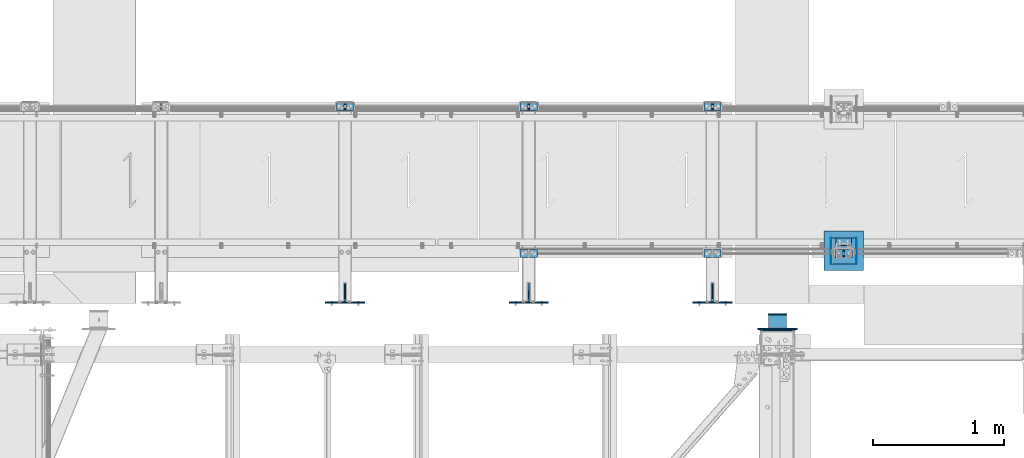
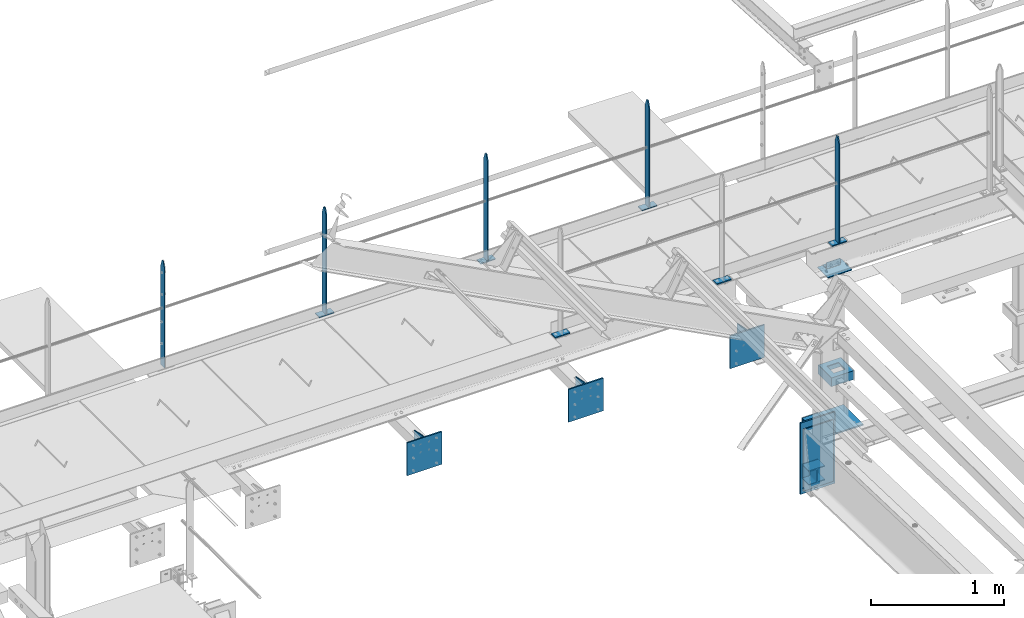
# One storey, part 96 of 496: 29 beams, 11 elements without a shape of their own.
"""IFC2X3 building model written with IfcOpenShell, lengths in millimetres."""

from ifc_helpers import new_model, si_unit, frame, origin_with_axes, origin_2d_with_axis, place, context, subcontext, project, spatial, polyline, rectangle, i_section, l_section, u_section, outline, extrude, boolean, clip, halfspace, material, type_object, element, aggregate, save


model = new_model("IFC2X3")

# Units and contexts
model_context = context("Model", 3, precision=1e-05, world=origin_with_axes())
body_context = subcontext(model_context, "Body", "Model", "MODEL_VIEW")
ifc_project = project(units=[si_unit("LENGTHUNIT", "METRE", prefix="MILLI"), si_unit("AREAUNIT", "SQUARE_METRE"), si_unit("VOLUMEUNIT", "CUBIC_METRE"), si_unit("MASSUNIT", "GRAM", prefix="KILO"), si_unit("TIMEUNIT", "SECOND"), si_unit("PLANEANGLEUNIT", "RADIAN"), si_unit("SOLIDANGLEUNIT", "STERADIAN"), si_unit("THERMODYNAMICTEMPERATUREUNIT", "DEGREE_CELSIUS"), si_unit("LUMINOUSINTENSITYUNIT", "LUMEN")], contexts=[model_context])

# Site, building, storey
site_placement = place(None, origin_with_axes())
site = spatial("IfcSite", under=ifc_project, at=site_placement, CompositionType="ELEMENT")
building_placement = place(site_placement, origin_with_axes())
building = spatial("IfcBuilding", under=site, at=building_placement, Name="Undefined", CompositionType="ELEMENT")
storey_placement = place(building_placement, origin_with_axes())
storey = spatial("IfcBuildingStorey", under=building, at=storey_placement, Name="Undefined", CompositionType="ELEMENT", Elevation=0.0)

# Assembly, beams
assembly_1_placement = place(storey_placement, origin_with_axes())
assembly_1 = element("IfcElementAssembly", 1, at=assembly_1_placement, inside=storey, Name="MAIN COURANTE", AssemblyPlace="NOTDEFINED", PredefinedType="NOTDEFINED")
ifc_material_1 = material(Name="Undefined/S235-E24")
beam_type_1 = type_object("IfcBeamType", PredefinedType="NOTDEFINED")
beam_1_placement = place(assembly_1_placement, frame((20119.9961849157, 15970.0000882977, 8705.00000001012), z_axis=(0.0, -1.0, 0.0), x_axis=(-1.0, 0.0, 0.0)))
beam_1 = element("IfcBeam", 2, at=beam_1_placement, type_object=beam_type_1, material=ifc_material_1, context=body_context, shape_type="SweptSolid", body=[
    extrude(rectangle(XDim=10.0, YDim=60.0, at=origin_2d_with_axis()), frame((130.0, 0.0, 0.0), z_axis=(-1.0, 0.0, 0.0), x_axis=(0.0, -1.0, 0.0)), (0.0, 0.0, 1.0), 130.0),
])
beam_2_placement = place(assembly_1_placement, frame((20054.9961849157, 15970.0000882977, 9677.59999847), z_axis=(0.0, 1.0, 0.0), x_axis=(0.0, 0.0, -1.0)))
beam_2 = element("IfcBeam", 3, at=beam_2_placement, type_object=beam_type_1, material=ifc_material_1, Name="MONTANT", context=body_context, shape_type="Clipping", body=[
    clip(clip(extrude(rectangle(XDim=10.0, YDim=60.0, at=origin_2d_with_axis()), frame((967.59999845988, 0.0, 0.0), z_axis=(-1.0, 0.0, 0.0), x_axis=(0.0, -1.0, 0.0)), (0.0, 0.0, 1.0), 967.6), halfspace(frame((-120.0, -5.0, -30.0), z_axis=(-0.316227766016838, 0.0, 0.948683298050514), x_axis=(0.0, 1.0, 0.0)), False)), halfspace(frame((60.0, -5.0, -30.0), z_axis=(-0.316227766016838, 0.0, -0.948683298050514), x_axis=(0.0, 1.0, 0.0)), False)),
])
beam_3_placement = place(assembly_1_placement, frame((19119.9961849193, 15970.0000882977, 8705.00000001012), z_axis=(0.0, -1.0, 0.0), x_axis=(-1.0, 0.0, 0.0)))
beam_3 = element("IfcBeam", 4, at=beam_3_placement, type_object=beam_type_1, material=ifc_material_1, context=body_context, shape_type="SweptSolid", body=[
    extrude(rectangle(XDim=10.0, YDim=60.0, at=origin_2d_with_axis()), frame((130.0, 0.0, 0.0), z_axis=(-1.0, 0.0, 0.0), x_axis=(0.0, -1.0, 0.0)), (0.0, 0.0, 1.0), 130.0),
])
aggregate(assembly_1, [beam_1, beam_2, beam_3])

# Assembly, beam
assembly_2_placement = place(storey_placement, origin_with_axes())
assembly_2 = element("IfcElementAssembly", 5, at=assembly_2_placement, inside=storey, AssemblyPlace="NOTDEFINED", PredefinedType="NOTDEFINED")
beam_4_placement = place(assembly_2_placement, frame((17719.9961849193, 15970.0000882977, 8705.00000001012), z_axis=(0.0, -1.0, 0.0), x_axis=(-1.0, 0.0, 0.0)))
beam_4 = element("IfcBeam", 6, at=beam_4_placement, type_object=beam_type_1, material=ifc_material_1, context=body_context, shape_type="SweptSolid", body=[
    extrude(rectangle(XDim=10.0, YDim=60.0, at=origin_2d_with_axis()), frame((130.0, 0.0, 0.0), z_axis=(-1.0, 0.0, 0.0), x_axis=(0.0, -1.0, 0.0)), (0.0, 0.0, 1.0), 130.0),
])
aggregate(assembly_2, [beam_4])

# Assembly, beams
assembly_3_placement = place(storey_placement, origin_with_axes())
assembly_3 = element("IfcElementAssembly", 7, at=assembly_3_placement, inside=storey, Name="MAIN COURANTE", AssemblyPlace="NOTDEFINED", PredefinedType="NOTDEFINED")
beam_5_placement = place(assembly_3_placement, frame((19119.9961849193, 17089.9938659712, 8705.00000001012), z_axis=(0.0, 1.0, 0.0), x_axis=(-1.0, 0.0, 0.0)))
beam_5 = element("IfcBeam", 8, at=beam_5_placement, type_object=beam_type_1, material=ifc_material_1, context=body_context, shape_type="SweptSolid", body=[
    extrude(rectangle(XDim=10.0, YDim=60.0, at=origin_2d_with_axis()), frame((130.0, 0.0, 0.0), z_axis=(-1.0, 0.0, 0.0), x_axis=(0.0, -1.0, 0.0)), (0.0, 0.0, 1.0), 130.0),
])
beam_6_placement = place(assembly_3_placement, frame((17719.9961849193, 17089.9938659712, 8705.00000001012), z_axis=(0.0, 1.0, 0.0), x_axis=(-1.0, 0.0, 0.0)))
beam_6 = element("IfcBeam", 9, at=beam_6_placement, type_object=beam_type_1, material=ifc_material_1, context=body_context, shape_type="SweptSolid", body=[
    extrude(rectangle(XDim=10.0, YDim=60.0, at=origin_2d_with_axis()), frame((130.0, 0.0, 0.0), z_axis=(-1.0, 0.0, 0.0), x_axis=(0.0, -1.0, 0.0)), (0.0, 0.0, 1.0), 130.0),
])
beam_7_placement = place(assembly_3_placement, frame((16319.9961849193, 17089.9938659712, 8705.00000001012), z_axis=(0.0, 1.0, 0.0), x_axis=(-1.0, 0.0, 0.0)))
beam_7 = element("IfcBeam", 10, at=beam_7_placement, type_object=beam_type_1, material=ifc_material_1, context=body_context, shape_type="SweptSolid", body=[
    extrude(rectangle(XDim=10.0, YDim=60.0, at=origin_2d_with_axis()), frame((130.0, 0.0, 0.0), z_axis=(-1.0, 0.0, 0.0), x_axis=(0.0, -1.0, 0.0)), (0.0, 0.0, 1.0), 130.0),
])
beam_8_placement = place(assembly_3_placement, frame((16254.9961849193, 17089.9938659712, 9677.59999847), z_axis=(0.0, -1.0, 0.0), x_axis=(0.0, 0.0, -1.0)))
beam_8 = element("IfcBeam", 11, at=beam_8_placement, type_object=beam_type_1, material=ifc_material_1, Name="MONTANT", context=body_context, shape_type="Clipping", body=[
    clip(clip(extrude(rectangle(XDim=10.0, YDim=60.0, at=origin_2d_with_axis()), frame((967.59999845988, 0.0, 0.0), z_axis=(-1.0, 0.0, 0.0), x_axis=(0.0, -1.0, 0.0)), (0.0, 0.0, 1.0), 967.6), halfspace(frame((-120.0, 5.0, -30.0), z_axis=(-0.316227766016838, 0.0, 0.948683298050514), x_axis=(0.948683298050514, 0.0, 0.316227766016838)), False)), halfspace(frame((60.0, 5.0, -30.0), z_axis=(-0.316227766016838, 0.0, -0.948683298050514), x_axis=(-0.948683298050514, 0.0, 0.316227766016838)), False)),
])
beam_9_placement = place(assembly_3_placement, frame((17654.9961849193, 17089.9938659712, 9677.59999847), z_axis=(0.0, -1.0, 0.0), x_axis=(0.0, 0.0, -1.0)))
beam_9 = element("IfcBeam", 12, at=beam_9_placement, type_object=beam_type_1, material=ifc_material_1, Name="MONTANT", context=body_context, shape_type="Clipping", body=[
    clip(clip(extrude(rectangle(XDim=10.0, YDim=60.0, at=origin_2d_with_axis()), frame((967.59999845988, 0.0, 0.0), z_axis=(-1.0, 0.0, 0.0), x_axis=(0.0, -1.0, 0.0)), (0.0, 0.0, 1.0), 967.6), halfspace(frame((-120.0, 5.0, -30.0), z_axis=(-0.316227766016838, 0.0, 0.948683298050514), x_axis=(0.948683298050514, 0.0, 0.316227766016838)), False)), halfspace(frame((60.0, 5.0, -30.0), z_axis=(-0.316227766016838, 0.0, -0.948683298050514), x_axis=(-0.948683298050514, 0.0, 0.316227766016838)), False)),
])
beam_10_placement = place(assembly_3_placement, frame((19054.9961849193, 17089.9938659712, 9677.59999847), z_axis=(0.0, -1.0, 0.0), x_axis=(0.0, 0.0, -1.0)))
beam_10 = element("IfcBeam", 13, at=beam_10_placement, type_object=beam_type_1, material=ifc_material_1, Name="MONTANT", context=body_context, shape_type="Clipping", body=[
    clip(clip(extrude(rectangle(XDim=10.0, YDim=60.0, at=origin_2d_with_axis()), frame((967.59999845988, 0.0, 0.0), z_axis=(-1.0, 0.0, 0.0), x_axis=(0.0, -1.0, 0.0)), (0.0, 0.0, 1.0), 967.6), halfspace(frame((-120.0, 5.0, -30.0), z_axis=(-0.316227766016838, 0.0, 0.948683298050514), x_axis=(0.948683298050514, 0.0, 0.316227766016838)), False)), halfspace(frame((60.0, 5.0, -30.0), z_axis=(-0.316227766016838, 0.0, -0.948683298050514), x_axis=(-0.948683298050514, 0.0, 0.316227766016838)), False)),
])
aggregate(assembly_3, [beam_5, beam_6, beam_7, beam_8, beam_9, beam_10])

# Assembly, beam
assembly_4_placement = place(storey_placement, origin_with_axes())
assembly_4 = element("IfcElementAssembly", 14, at=assembly_4_placement, inside=storey, Name="CONSOLE", AssemblyPlace="NOTDEFINED", PredefinedType="NOTDEFINED")
beam_type_2 = type_object("IfcBeamType", PredefinedType="NOTDEFINED")
beam_11_placement = place(assembly_4_placement, frame((19055.0007605158, 15622.0, 8175.0), z_axis=(-1.0, 0.0, 0.0), x_axis=(0.0, -1.0, 0.0)))
beam_11 = element("IfcBeam", 15, at=beam_11_placement, type_object=beam_type_2, material=ifc_material_1, Name="CONSOLE", context=body_context, shape_type="SweptSolid", body=[
    extrude(outline(polyline([(0.0, 0.0), (20.0, 0.0), (20.0, 300.0), (0.0, 300.0), (-118.0, 275.0), (-118.0, 155.0), (0.0, 0.0)])), frame((0.0, 0.0, -4.0), z_axis=(0.0, 0.0, 1.0), x_axis=(1.0, 0.0, 0.0)), (0.0, 0.0, 1.0), 8.0),
])

assembly_5_placement = place(storey_placement, origin_with_axes())
assembly_5 = element("IfcElementAssembly", 16, at=assembly_5_placement, inside=storey, Name="CONSOLE", AssemblyPlace="NOTDEFINED", PredefinedType="NOTDEFINED")
beam_12_placement = place(assembly_5_placement, frame((17655.0007605158, 15622.0, 8175.0), z_axis=(-1.0, 0.0, 0.0), x_axis=(0.0, -1.0, 0.0)))
beam_12 = element("IfcBeam", 17, at=beam_12_placement, type_object=beam_type_2, material=ifc_material_1, Name="CONSOLE", context=body_context, shape_type="SweptSolid", body=[
    extrude(outline(polyline([(0.0, 0.0), (20.0, 0.0), (20.0, 300.0), (0.0, 300.0), (-118.0, 275.0), (-118.0, 155.0), (0.0, 0.0)])), frame((0.0, 0.0, -4.0), z_axis=(0.0, 0.0, 1.0), x_axis=(1.0, 0.0, 0.0)), (0.0, 0.0, 1.0), 8.0),
])

assembly_6_placement = place(storey_placement, origin_with_axes())
assembly_6 = element("IfcElementAssembly", 18, at=assembly_6_placement, inside=storey, Name="CONSOLE", AssemblyPlace="NOTDEFINED", PredefinedType="NOTDEFINED")
beam_13_placement = place(assembly_6_placement, frame((16255.0007605158, 15622.0, 8175.0), z_axis=(-1.0, 0.0, 0.0), x_axis=(0.0, -1.0, 0.0)))
beam_13 = element("IfcBeam", 19, at=beam_13_placement, type_object=beam_type_2, material=ifc_material_1, Name="CONSOLE", context=body_context, shape_type="SweptSolid", body=[
    extrude(outline(polyline([(0.0, 0.0), (20.0, 0.0), (20.0, 300.0), (0.0, 300.0), (-118.0, 275.0), (-118.0, 155.0), (0.0, 0.0)])), frame((0.0, 0.0, -4.0), z_axis=(0.0, 0.0, 1.0), x_axis=(1.0, 0.0, 0.0)), (0.0, 0.0, 1.0), 8.0),
])

assembly_7_placement = place(storey_placement, origin_with_axes())
assembly_7 = element("IfcElementAssembly", 20, at=assembly_7_placement, inside=storey, AssemblyPlace="NOTDEFINED", PredefinedType="NOTDEFINED")
beam_type_3 = type_object("IfcBeamType", PredefinedType="NOTDEFINED")
beam_14_placement = place(assembly_7_placement, frame((20205.0, 15840.0001225752, 7056.0), z_axis=(0.0, 0.0, -1.0), x_axis=(-1.0, 0.0, 0.0)))
beam_14 = element("IfcBeam", 21, at=beam_14_placement, type_object=beam_type_3, material=ifc_material_1, context=body_context, shape_type="SweptSolid", body=[
    extrude(outline(polyline([(0.0, 0.0), (300.0, 0.0), (300.0, 300.0), (0.0, 300.0), (0.0, 0.0)])), frame((0.0, 0.0, -6.0), z_axis=(0.0, 0.0, 1.0), x_axis=(1.0, 0.0, 0.0)), (0.0, 0.0, 1.0), 12.0),
])

# Beam
beam_15_placement = place(assembly_4_placement, frame((19055.0007605158, 15595.99984642, 8475.0), z_axis=(1.0, 0.0, 0.0), x_axis=(0.0, 0.0, -1.0)))
beam_15 = element("IfcBeam", 22, at=beam_15_placement, type_object=beam_type_3, material=ifc_material_1, Name="CONSOLE", context=body_context, shape_type="SweptSolid", body=[
    extrude(rectangle(XDim=12.0, YDim=300.0, at=origin_2d_with_axis()), frame((300.0, 0.0, 0.0), z_axis=(-1.0, 0.0, 0.0), x_axis=(0.0, -1.0, 0.0)), (0.0, 0.0, 1.0), 300.0),
])

aggregate(assembly_4, [beam_11, beam_15])

beam_16_placement = place(assembly_5_placement, frame((17655.0007605158, 15595.99984642, 8475.0), z_axis=(1.0, 0.0, 0.0), x_axis=(0.0, 0.0, -1.0)))
beam_16 = element("IfcBeam", 23, at=beam_16_placement, type_object=beam_type_3, material=ifc_material_1, Name="CONSOLE", context=body_context, shape_type="SweptSolid", body=[
    extrude(rectangle(XDim=12.0, YDim=300.0, at=origin_2d_with_axis()), frame((300.0, 0.0, 0.0), z_axis=(-1.0, 0.0, 0.0), x_axis=(0.0, -1.0, 0.0)), (0.0, 0.0, 1.0), 300.0),
])

aggregate(assembly_5, [beam_12, beam_16])

beam_17_placement = place(assembly_6_placement, frame((16255.0007605158, 15595.99984642, 8475.0), z_axis=(1.0, 0.0, 0.0), x_axis=(0.0, 0.0, -1.0)))
beam_17 = element("IfcBeam", 24, at=beam_17_placement, type_object=beam_type_3, material=ifc_material_1, Name="CONSOLE", context=body_context, shape_type="SweptSolid", body=[
    extrude(rectangle(XDim=12.0, YDim=300.0, at=origin_2d_with_axis()), frame((300.0, 0.0, 0.0), z_axis=(-1.0, 0.0, 0.0), x_axis=(0.0, -1.0, 0.0)), (0.0, 0.0, 1.0), 300.0),
])

aggregate(assembly_6, [beam_13, beam_17])

# Assembly, beam
assembly_8_placement = place(storey_placement, origin_with_axes())
assembly_8 = element("IfcElementAssembly", 25, at=assembly_8_placement, inside=storey, AssemblyPlace="NOTDEFINED", PredefinedType="NOTDEFINED")
beam_18_placement = place(assembly_8_placement, frame((19550.000000027, 15396.0000000013, 7624.99732627141), z_axis=(-1.0, 0.0, 0.0), x_axis=(0.0, 0.0, -1.0)))
beam_18 = element("IfcBeam", 26, at=beam_18_placement, type_object=beam_type_3, material=ifc_material_1, context=body_context, shape_type="SweptSolid", body=[
    extrude(rectangle(XDim=12.0, YDim=300.0, at=origin_2d_with_axis()), frame((654.999999999754, 0.0, 0.0), z_axis=(-1.0, 0.0, 0.0), x_axis=(0.0, -1.0, 0.0)), (0.0, 0.0, 1.0), 655.0),
])

assembly_9_placement = place(storey_placement, origin_with_axes())
assembly_9 = element("IfcElementAssembly", 27, at=assembly_9_placement, inside=storey, Name="MAIN COURANTE", AssemblyPlace="NOTDEFINED", PredefinedType="NOTDEFINED")
beam_type_4 = type_object("IfcBeamType", PredefinedType="NOTDEFINED")
beam_19_placement = place(assembly_9_placement, frame((14852.4961849193, 17089.9938659712, 9677.59999847), z_axis=(0.0, -1.0, 0.0), x_axis=(0.0, 0.0, -1.0)))
beam_19 = element("IfcBeam", 28, at=beam_19_placement, type_object=beam_type_4, material=ifc_material_1, Name="MONTANT", context=body_context, shape_type="Clipping", body=[
    clip(clip(extrude(rectangle(XDim=5.0, YDim=60.0, at=origin_2d_with_axis()), frame((967.59999845988, 0.0, 0.0), z_axis=(-1.0, 0.0, 0.0), x_axis=(0.0, -1.0, 0.0)), (0.0, 0.0, 1.0), 967.6), halfspace(frame((-120.0, 5.0, -30.0), z_axis=(-0.316227766016838, 0.0, 0.948683298050514), x_axis=(0.948683298050514, 0.0, 0.316227766016838)), False)), halfspace(frame((60.0, 5.0, -30.0), z_axis=(-0.316227766016838, 0.0, -0.948683298050514), x_axis=(-0.948683298050514, 0.0, 0.316227766016838)), False)),
])
aggregate(assembly_9, [beam_19])

# Beam
beam_type_5 = type_object("IfcBeamType", PredefinedType="NOTDEFINED")
beam_20_placement = place(assembly_7_placement, frame((20160.0, 15930.0006414961, 8436.00011661134), z_axis=(0.0, 0.0, -1.0), x_axis=(-1.0, 0.0, 0.0)))
beam_20 = element("IfcBeam", 29, at=beam_20_placement, type_object=beam_type_5, material=ifc_material_1, context=body_context, shape_type="SweptSolid", body=[
    extrude(outline(polyline([(0.0, 0.0), (210.0, 0.0), (210.0, 159.999481201172), (0.0, 159.999481201172), (0.0, 0.0)])), frame((0.0, 0.0, -4.0), z_axis=(0.0, 0.0, 1.0), x_axis=(1.0, 0.0, 0.0)), (0.0, 0.0, 1.0), 8.0),
])

beam_type_6 = type_object("IfcBeamType", PredefinedType="NOTDEFINED")
beam_21_placement = place(assembly_7_placement, frame((20153.0, 16090.0001225752, 7500.0), z_axis=(0.0, 0.0, 1.0), x_axis=(0.0, -1.0, 0.0)))
beam_21 = element("IfcBeam", 30, at=beam_21_placement, type_object=beam_type_6, material=ifc_material_1, Name="BORD", context=body_context, shape_type="SweptSolid", body=[
    extrude(rectangle(XDim=4.0, YDim=80.0, at=origin_2d_with_axis()), frame((200.0, 0.0, 0.0), z_axis=(-1.0, 0.0, 0.0), x_axis=(0.0, -1.0, 0.0)), (0.0, 0.0, 1.0), 200.0),
])

beam_22_placement = place(assembly_7_placement, frame((19957.0, 16090.0001225752, 7500.0), z_axis=(0.0, 0.0, 1.0), x_axis=(0.0, -1.0, 0.0)))
beam_22 = element("IfcBeam", 31, at=beam_22_placement, type_object=beam_type_6, material=ifc_material_1, Name="BORD", context=body_context, shape_type="SweptSolid", body=[
    extrude(rectangle(XDim=4.0, YDim=80.0, at=origin_2d_with_axis()), frame((200.0, 0.0, 0.0), z_axis=(-1.0, 0.0, 0.0), x_axis=(0.0, -1.0, 0.0)), (0.0, 0.0, 1.0), 200.0),
])

beam_type_7 = type_object("IfcBeamType", PredefinedType="NOTDEFINED")
beam_23_placement = place(assembly_7_placement, frame((20151.0, 15990.0001225752, 7500.0), z_axis=(0.0, 1.0, 0.0), x_axis=(-1.0, 0.0, 0.0)))
beam_23 = element("IfcBeam", 32, at=beam_23_placement, type_object=beam_type_7, material=ifc_material_1, context=body_context, shape_type="CSG", body=[
    boolean("DIFFERENCE", extrude(u_section(Depth=200.0, FlangeWidth=80.0, WebThickness=4.0, FlangeThickness=4.0, at=origin_2d_with_axis()), frame((192.0, 0.0, 0.0), z_axis=(-1.0, 0.0, 0.0), x_axis=(0.0, -1.0, 0.0)), (0.0, 0.0, 1.0), 192.0), extrude(outline(polyline([(0.0, 0.0), (101.0, 0.0), (101.0, 101.0), (0.0, 101.0), (0.0, 0.0)])), frame((146.5, -42.5, 50.5), z_axis=(0.0, 1.0, 0.0), x_axis=(0.0, 0.0, -1.0)), (0.0, 0.0, 1.0), 85.0)),
])

aggregate(assembly_7, [beam_20, beam_21, beam_22, beam_23, beam_14])

# Assembly, beam
assembly_10_placement = place(storey_placement, origin_with_axes())
assembly_10 = element("IfcElementAssembly", 33, at=assembly_10_placement, inside=storey, AssemblyPlace="NOTDEFINED", PredefinedType="NOTDEFINED")
beam_type_8 = type_object("IfcBeamType", PredefinedType="NOTDEFINED")
beam_24_placement = place(assembly_10_placement, frame((20115.0, 16060.0001225625, 8470.0), z_axis=(0.0, 0.0, 1.0), x_axis=(-1.0, 0.0, 0.0)))
beam_24 = element("IfcBeam", 34, at=beam_24_placement, type_object=beam_type_8, material=ifc_material_1, context=body_context, shape_type="SweptSolid", body=[
    extrude(l_section(Depth=60.0, Width=60.0, Thickness=6.0, FilletRadius=8.0, EdgeRadius=4.0, at=origin_2d_with_axis()), frame((120.0, 0.0, 0.0), z_axis=(-1.0, 0.0, 0.0), x_axis=(0.0, -1.0, 0.0)), (0.0, 0.0, 1.0), 120.0),
])
aggregate(assembly_10, [beam_24])

# Beam
beam_type_9 = type_object("IfcBeamType", PredefinedType="NOTDEFINED")
beam_25_placement = place(assembly_8_placement, frame((19550.0000000283, 15507.0000000015, 7151.49732627159), z_axis=(-1.0, 0.0, 0.0), x_axis=(0.0, 0.0, -1.0)))
beam_25 = element("IfcBeam", 35, at=beam_25_placement, type_object=beam_type_9, material=ifc_material_1, Name="PLAT", context=body_context, shape_type="SweptSolid", body=[
    extrude(rectangle(XDim=10.0, YDim=140.0, at=origin_2d_with_axis()), frame((132.999999999945, 0.0, 0.0), z_axis=(-1.0, 0.0, 0.0), x_axis=(0.0, -1.0, 0.0)), (0.0, 0.0, 1.0), 133.0),
])

beam_26_placement = place(assembly_8_placement, frame((19550.0000000282, 15507.0000000014, 7576.49732627143), z_axis=(-1.0, 0.0, 0.0), x_axis=(0.0, 0.0, -1.0)))
beam_26 = element("IfcBeam", 36, at=beam_26_placement, type_object=beam_type_9, material=ifc_material_1, Name="PLAT", context=body_context, shape_type="SweptSolid", body=[
    extrude(rectangle(XDim=10.0, YDim=140.0, at=origin_2d_with_axis()), frame((132.999999999945, 0.0, 0.0), z_axis=(-1.0, 0.0, 0.0), x_axis=(0.0, -1.0, 0.0)), (0.0, 0.0, 1.0), 133.0),
])

ifc_material_2 = material(Name="Undefined/S275-E28")
beam_type_10 = type_object("IfcBeamType", Name="HEA140", PredefinedType="NOTDEFINED")
beam_27_placement = place(assembly_8_placement, frame((19550.0000000269, 15402.0000000013, 7084.99732627159), z_axis=(0.0, 0.0, 1.0), x_axis=(0.0, 1.0, 0.0)))
beam_27 = element("IfcBeam", 37, at=beam_27_placement, type_object=beam_type_10, material=ifc_material_2, ObjectType="HEA140", context=body_context, shape_type="SweptSolid", body=[
    extrude(i_section(OverallWidth=140.0, OverallDepth=133.0, WebThickness=5.5, FlangeThickness=8.5, FilletRadius=12.0, at=origin_2d_with_axis()), frame((100.000000000021, 5.72981662116945e-11, -4.09272615797818e-12), z_axis=(-1.0, 0.0, 0.0), x_axis=(0.0, -1.0, 0.0)), (0.0, 0.0, 1.0), 100.0),
])

beam_28_placement = place(assembly_8_placement, frame((19550.000000027, 15402.0000000012, 7509.99732627145), z_axis=(0.0, 0.0, 1.0), x_axis=(0.0, 1.0, 0.0)))
beam_28 = element("IfcBeam", 38, at=beam_28_placement, type_object=beam_type_10, material=ifc_material_2, ObjectType="HEA140", context=body_context, shape_type="SweptSolid", body=[
    extrude(i_section(OverallWidth=140.0, OverallDepth=133.0, WebThickness=5.5, FlangeThickness=8.5, FilletRadius=12.0, at=origin_2d_with_axis()), frame((100.000000000021, 5.72981662116945e-11, -4.09272615797818e-12), z_axis=(-1.0, 0.0, 0.0), x_axis=(0.0, -1.0, 0.0)), (0.0, 0.0, 1.0), 100.0),
])

aggregate(assembly_8, [beam_25, beam_27, beam_26, beam_28, beam_18])

# Assembly, beam
assembly_11_placement = place(storey_placement, origin_with_axes())
assembly_11 = element("IfcElementAssembly", 39, at=assembly_11_placement, inside=storey, AssemblyPlace="NOTDEFINED", PredefinedType="NOTDEFINED")
beam_type_11 = type_object("IfcBeamType", PredefinedType="NOTDEFINED")
beam_29_placement = place(assembly_11_placement, frame((19550.0000000257, 15385.0000000017, 7564.99732627142), z_axis=(-1.0, 0.0, 0.0), x_axis=(0.0, 0.0, -1.0)))
beam_29 = element("IfcBeam", 40, at=beam_29_placement, type_object=beam_type_11, material=ifc_material_1, context=body_context, shape_type="SweptSolid", body=[
    extrude(rectangle(XDim=10.0, YDim=260.0, at=origin_2d_with_axis()), frame((564.999999999777, 0.0, 0.0), z_axis=(-1.0, 0.0, 0.0), x_axis=(0.0, -1.0, 0.0)), (0.0, 0.0, 1.0), 565.0),
])
aggregate(assembly_11, [beam_29])

save(model, "model.ifc")
